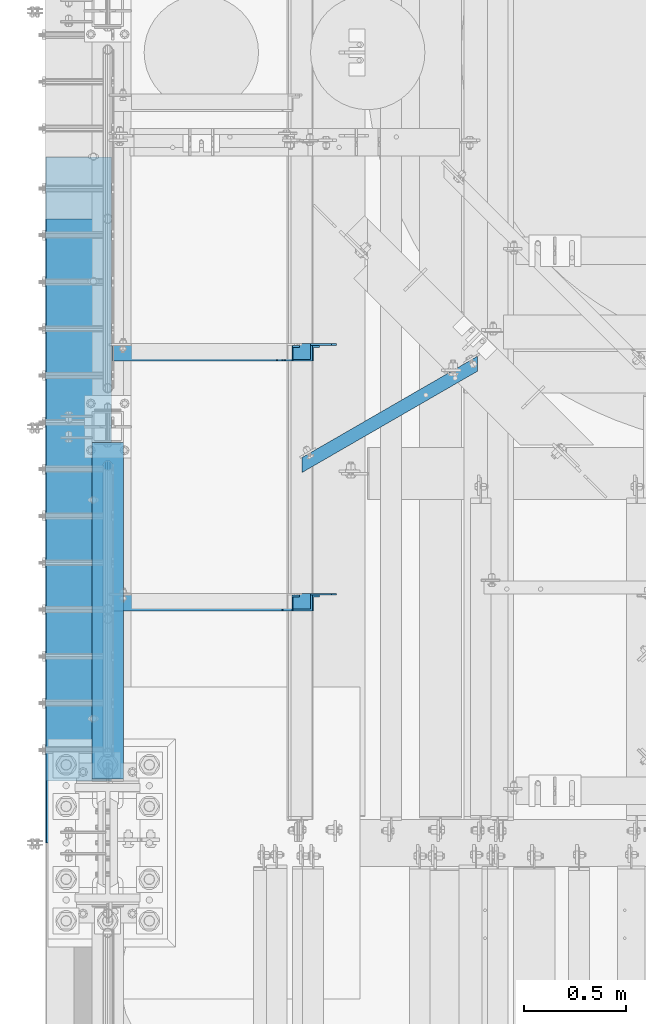
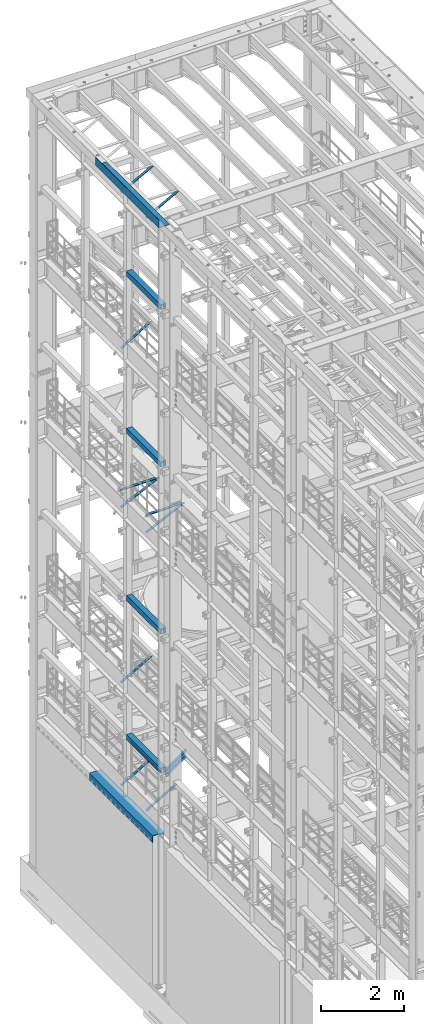
# One storey, part 1043 of 1876: 10 beams, 8 members, 18 elements without a shape of their own.
"""IFC2X3 building model written with IfcOpenShell, lengths in millimetres."""

import ifcopenshell
import ifcopenshell.guid

model = None  # the IFC model being written
_history = None  # IfcOwnerHistory: only IFC2X3 demands one
_inside = {}  # id of a spatial element -> (the spatial element, [elements in it])
_under = {}  # id of a project, library or spatial element -> (it, [spatial elements below it])
_declared = {}  # id of a project -> (the project, [libraries it declares])
_typed = {}  # id of a type object -> (the type object, [elements of that type])
_made_of = {}  # id of a material, layer set ... -> (it, [elements and type objects made of it])


def new_model(schema):
    """Start an empty IFC model of exactly this schema.

    Asked for "IFC4X3", IfcOpenShell would pick the latest addendum, in which some entities
    have other attributes; the version numbers below select the first issue.
    IFC2X3 requires an IfcOwnerHistory on every rooted entity: one is made here for all.
    """
    global model, _history
    if schema == "IFC4X3":
        model = ifcopenshell.file(schema_version=(4, 3, 0, 0))
    else:
        model = ifcopenshell.file(schema=schema)
    _inside.clear()
    _under.clear()
    _declared.clear()
    _typed.clear()
    _made_of.clear()
    _history = None
    if model.schema == "IFC2X3":
        org = make("IfcOrganization", Name="unknown")
        user = make(
            "IfcPersonAndOrganization",
            ThePerson=make("IfcPerson", FamilyName="unknown"),
            TheOrganization=org,
        )
        app = make(
            "IfcApplication",
            ApplicationDeveloper=org,
            Version="unknown",
            ApplicationFullName="unknown",
            ApplicationIdentifier="unknown",
        )
        _history = make(
            "IfcOwnerHistory",
            OwningUser=user,
            OwningApplication=app,
            ChangeAction="ADDED",
            CreationDate=0,
        )
    return model


def make(cls, **values):
    """One entity of the class cls with the attributes given. An attribute that is None is left unset."""
    return model.create_entity(
        cls, **{name: value for name, value in values.items() if value is not None}
    )


def rooted(cls, **values):
    """An entity with a GlobalId (a new one), such as an element, a storey or a relation."""
    return make(cls, GlobalId=ifcopenshell.guid.new(), OwnerHistory=_history, **values)


def si_unit(unit_type, name, prefix=None):
    """IfcSIUnit, for example si_unit("LENGTHUNIT", "METRE", prefix="MILLI")."""
    return make("IfcSIUnit", UnitType=unit_type, Prefix=prefix, Name=name)


def assignment(units):
    """IfcUnitAssignment: the units of a project."""
    return None if units is None else make("IfcUnitAssignment", Units=units)


def point(xyz):
    """IfcCartesianPoint."""
    return None if xyz is None else make("IfcCartesianPoint", Coordinates=xyz)


def direction(xyz):
    """IfcDirection."""
    return None if xyz is None else make("IfcDirection", DirectionRatios=xyz)


def frame(location, z_axis=None, x_axis=None):
    """IfcAxis2Placement3D, a coordinate frame: its origin and axes. An axis left out is left unset."""
    return make(
        "IfcAxis2Placement3D",
        Location=point(location),
        Axis=direction(z_axis),
        RefDirection=direction(x_axis),
    )


def origin_with_axes():
    """The frame at (0, 0, 0) with the z axis (0, 0, 1) and the x axis (1, 0, 0) written out."""
    return frame((0.0, 0.0, 0.0), z_axis=(0.0, 0.0, 1.0), x_axis=(1.0, 0.0, 0.0))


def place(relative_to, where):
    """IfcLocalPlacement: puts the frame where relative to a parent placement (None: the world)."""
    return make(
        "IfcLocalPlacement", PlacementRelTo=relative_to, RelativePlacement=where
    )


def context(
    kind, dimensions, precision=None, world=None, true_north=None, identifier=None
):
    """IfcGeometricRepresentationContext, for example the 3D "Model" context."""
    return make(
        "IfcGeometricRepresentationContext",
        ContextIdentifier=identifier,
        ContextType=kind,
        CoordinateSpaceDimension=dimensions,
        Precision=precision,
        WorldCoordinateSystem=world,
        TrueNorth=true_north,
    )


def subcontext(parent, identifier, kind, view, scale=None):
    """IfcGeometricRepresentationSubContext, for example "Body" below "Model"."""
    return make(
        "IfcGeometricRepresentationSubContext",
        ContextIdentifier=identifier,
        ContextType=kind,
        ParentContext=parent,
        TargetScale=scale,
        TargetView=view,
    )


def project(units=None, contexts=None):
    """IfcProject with its units and contexts."""
    return rooted(
        "IfcProject",
        Name="project",
        RepresentationContexts=contexts,
        UnitsInContext=assignment(units),
    )


def spatial(cls, under=None, at=None, **own):
    """A site, building, storey or space (cls), placed at a placement, below another one or the project."""
    s = rooted(cls, ObjectPlacement=at, **own)
    if under is not None:
        _under.setdefault(under.id(), (under, []))[1].append(s)
    return s


def faces_of(points, faces, orient=None, outer=None):
    """IfcFace entities. A face is a list of loops; a loop is a list of indices into points, from 0.

    orient and outer hold one flag for each loop. By default every Orientation is true, the
    first loop of a face is its IfcFaceOuterBound and the others are IfcFaceBound.
    """
    made = []
    for i, loops in enumerate(faces):
        bounds = []
        for j, loop in enumerate(loops):
            is_outer = j == 0 if outer is None else outer[i][j]
            bounds.append(
                make(
                    "IfcFaceOuterBound" if is_outer else "IfcFaceBound",
                    Bound=make("IfcPolyLoop", Polygon=[points[k] for k in loop]),
                    Orientation=True if orient is None else orient[i][j],
                )
            )
        made.append(make("IfcFace", Bounds=bounds))
    return made


def faceted_brep(points, faces, orient=None, outer=None, voids=None):
    """IfcFacetedBrep: a solid bounded by flat faces; with voids (closed shells), ...WithVoids."""
    shared = [point(p) for p in points]
    hull = make("IfcClosedShell", CfsFaces=faces_of(shared, faces, orient, outer))
    if voids is None:
        return make("IfcFacetedBrep", Outer=hull)
    return make(
        "IfcFacetedBrepWithVoids",
        Outer=hull,
        Voids=[
            make(cls, CfsFaces=faces_of(shared, fs, o, b)) for cls, fs, o, b in voids
        ],
    )


def shape(context_of_items, identifier, shape_type, items):
    """IfcShapeRepresentation: the items that make up one representation, for example the "Body"."""
    return make(
        "IfcShapeRepresentation",
        ContextOfItems=context_of_items,
        RepresentationIdentifier=identifier,
        RepresentationType=shape_type,
        Items=items,
    )


def material(Name=None, Category=None):
    """IfcMaterial."""
    return make("IfcMaterial", Name=Name, Category=Category)


def made_of(thing, what):
    """Note that an element or type object is made of a material, layer set ...; save() writes the relation."""
    if what is not None:
        _made_of.setdefault(what.id(), (what, []))[1].append(thing)
    return thing


def type_object(cls, material=None, **own):
    """A type object (cls), such as IfcWallType, which elements share."""
    return made_of(rooted(cls, **own), material)


def element(
    cls,
    number,
    at=None,
    inside=None,
    cuts=None,
    type_object=None,
    material=None,
    context=None,
    identifier="Body",
    shape_type=None,
    held_by="IfcProductDefinitionShape",
    body=None,
    shapes=None,
    **own,
):
    """One element of the class cls, such as IfcWall. Its Tag is "e" and its number.

    at: its placement. inside: the storey or other place that contains it. cuts: it is an
    opening in that element (IfcRelVoidsElement). A single representation is given by context,
    identifier, shape_type and body (its items); several are given by shapes. held_by: the class
    of the entity that holds the representations. save() writes the other relations.
    """
    e = rooted(cls, Tag="e%d" % number, ObjectPlacement=at, **own)
    if body is not None:
        shapes = [shape(context, identifier, shape_type, body)]
    if shapes is not None:
        e.Representation = make(held_by, Representations=shapes)
    if inside is not None:
        _inside.setdefault(inside.id(), (inside, []))[1].append(e)
    if cuts is not None:
        rooted(
            "IfcRelVoidsElement", RelatingBuildingElement=cuts, RelatedOpeningElement=e
        )
    if type_object is not None:
        _typed.setdefault(type_object.id(), (type_object, []))[1].append(e)
    return made_of(e, material)


def aggregate(whole, parts):
    """IfcRelAggregates: a whole, such as a stair, and the parts it consists of."""
    return rooted("IfcRelAggregates", RelatingObject=whole, RelatedObjects=parts)


def save(model, path):
    """Write the relations noted so far, then the file.

    IfcRelAggregates (storeys below a building ...), IfcRelContainedInSpatialStructure (elements
    in a storey), IfcRelDefinesByType, IfcRelAssociatesMaterial and IfcRelDeclares: one each for
    every whole, place, type object, material and project.
    """
    for whole, parts in _under.values():
        aggregate(whole, parts)
    for where, things in _inside.values():
        rooted(
            "IfcRelContainedInSpatialStructure",
            RelatedElements=things,
            RelatingStructure=where,
        )
    for kind, things in _typed.values():
        rooted("IfcRelDefinesByType", RelatedObjects=things, RelatingType=kind)
    for what, things in _made_of.values():
        rooted("IfcRelAssociatesMaterial", RelatedObjects=things, RelatingMaterial=what)
    for by, libraries in _declared.values():
        rooted("IfcRelDeclares", RelatingContext=by, RelatedDefinitions=libraries)
    model.write(path)


model = new_model("IFC2X3")

# Units and contexts
model_context = context("Model", 3, precision=1e-05, world=origin_with_axes())
body_context = subcontext(model_context, "Body", "Model", "MODEL_VIEW")
ifc_project = project(units=[si_unit("LENGTHUNIT", "METRE", prefix="MILLI"), si_unit("AREAUNIT", "SQUARE_METRE"), si_unit("VOLUMEUNIT", "CUBIC_METRE"), si_unit("MASSUNIT", "GRAM", prefix="KILO"), si_unit("TIMEUNIT", "SECOND"), si_unit("PLANEANGLEUNIT", "RADIAN"), si_unit("SOLIDANGLEUNIT", "STERADIAN"), si_unit("THERMODYNAMICTEMPERATUREUNIT", "DEGREE_CELSIUS"), si_unit("LUMINOUSINTENSITYUNIT", "LUMEN")], contexts=[model_context])

# Site, building, storey
site_placement = place(None, origin_with_axes())
site = spatial("IfcSite", under=ifc_project, at=site_placement, CompositionType="ELEMENT")
building_placement = place(site_placement, origin_with_axes())
building = spatial("IfcBuilding", under=site, at=building_placement, Name="Undefined", CompositionType="ELEMENT")
storey_placement = place(building_placement, origin_with_axes())
storey = spatial("IfcBuildingStorey", under=building, at=storey_placement, Name="Undefined", CompositionType="ELEMENT", Elevation=0.0)

# Assembly, beam
assembly_1_placement = place(storey_placement, origin_with_axes())
assembly_1 = element("IfcElementAssembly", 1, at=assembly_1_placement, inside=storey, Name="RAIL", AssemblyPlace="NOTDEFINED", PredefinedType="RIGID_FRAME")
ifc_material_1 = material()
beam_type_1 = type_object("IfcBeamType", Name="PIPE1-1/2SCH40", PredefinedType="NOTDEFINED")
beam_1_placement = place(assembly_1_placement, frame((-1.81898940354586e-12, 8035.925, 6207.125), z_axis=(0.0, 0.0, -1.0), x_axis=(0.0, 1.0, 0.0)))
beam_1 = element("IfcBeam", 2, at=beam_1_placement, type_object=beam_type_1, material=ifc_material_1, Name="RAIL", ObjectType="PIPE1-1/2SCH40", context=body_context, shape_type="Brep", body=[
    faceted_brep([(24.1300000000001, -20.4469999999999, 0.0), (34.3535000000002, -17.7076214311803, 10.2235000000001), (1416.6215, -17.7076214311801, 10.2235000000001), (1426.845, -20.4470000000001, 0.0), (41.8376214311802, -10.2235000000001, 17.7076214311819), (1409.13737856882, -10.2235000000001, 17.7076214311801), (44.5770000000002, 0.0, 20.4470000000001), (1406.398, 0.0, 20.4470000000001), (41.8376214311802, 10.2235000000001, 17.7076214311819), (1409.13737856882, 10.2235000000001, 17.7076214311801), (34.3535000000002, 17.7076214311803, 10.2235000000001), (1416.6215, 17.7076214311801, 10.2235000000001), (24.1300000000001, 20.4469999999999, 0.0), (1426.845, 20.4470000000001, 0.0), (13.9065000000001, 17.7076214311803, -10.2235000000001), (1437.0685, 17.7076214311801, -10.2235000000001), (6.42237856882002, 10.2235000000001, -17.7076214311819), (1444.55262143118, 10.2235000000001, -17.7076214311801), (3.68299999999999, 0.0, -20.4470000000001), (1447.292, 0.0, -20.4470000000001), (6.42237856882002, -10.2235000000001, -17.7076214311819), (1444.55262143118, -10.2235000000001, -17.7076214311801), (13.9065000000001, -17.7076214311803, -10.2235000000001), (1437.0685, -17.7076214311801, -10.2235000000001), (24.1299999999854, -24.1299999999992, 0.0), (12.0650000000064, -20.8971929933177, -12.0649999999987), (1438.91, -20.8971929933186, -12.0649999999996), (1426.845, -24.1300000000001, 0.0), (3.23280700668147, -12.0650000000001, -20.8971929933177), (1447.74219299332, -12.0649999999996, -20.8971929933186), (-1.45519152283669e-11, 0.0, -24.130000000001), (1450.975, 0.0, -24.1300000000001), (3.23280700668147, 12.0650000000001, -20.8971929933177), (1447.74219299332, 12.0649999999996, -20.8971929933186), (12.0650000000064, 20.8971929933177, -12.0649999999987), (1438.91, 20.8971929933186, -12.0649999999996), (24.1300000000047, 24.1299999999992, 0.0), (1426.845, 24.1300000000001, 0.0), (36.1949999999997, 20.8971929933184, 12.0649999999987), (1414.78, 20.8971929933186, 12.0649999999996), (45.0271929933187, 12.0650000000001, 20.8971929933177), (1405.94780700668, 12.0649999999996, 20.8971929933186), (48.2600000000002, 0.0, 24.130000000001), (1402.715, 0.0, 24.1300000000001), (45.0271929933187, -12.0650000000001, 20.8971929933177), (1405.94780700668, -12.0649999999996, 20.8971929933186), (36.1949999999997, -20.8971929933184, 12.0649999999987), (1414.78, -20.8971929933186, 12.0649999999996)], [[[0, 1, 2, 3]], [[1, 4, 5, 2]], [[4, 6, 7, 5]], [[6, 8, 9, 7]], [[8, 10, 11, 9]], [[10, 12, 13, 11]], [[12, 14, 15, 13]], [[14, 16, 17, 15]], [[16, 18, 19, 17]], [[18, 20, 21, 19]], [[20, 22, 23, 21]], [[22, 0, 3, 23]], [[24, 25, 26, 27]], [[25, 28, 29, 26]], [[28, 30, 31, 29]], [[30, 32, 33, 31]], [[32, 34, 35, 33]], [[34, 36, 37, 35]], [[36, 38, 39, 37]], [[38, 40, 41, 39]], [[40, 42, 43, 41]], [[42, 44, 45, 43]], [[44, 46, 47, 45]], [[46, 24, 27, 47]], [[29, 31, 33, 35, 37, 39, 41, 43, 45, 47, 27, 26], [5, 7, 9, 11, 13, 15, 17, 19, 21, 23, 3, 2]], [[46, 44, 42, 40, 38, 36, 34, 32, 30, 28, 25, 24], [22, 20, 18, 16, 14, 12, 10, 8, 6, 4, 1, 0]]]),
])
aggregate(assembly_1, [beam_1])

assembly_2_placement = place(storey_placement, origin_with_axes())
assembly_2 = element("IfcElementAssembly", 3, at=assembly_2_placement, inside=storey, Name="BEAM", AssemblyPlace="NOTDEFINED", PredefinedType="RIGID_FRAME")
ifc_material_2 = material()
beam_type_2 = type_object("IfcBeamType", Name="HSS6X6X3/8", PredefinedType="NOTDEFINED")
beam_2_placement = place(assembly_2_placement, frame((0.0, 7908.925, 19958.05), z_axis=(-1.0, 0.0, 0.0), x_axis=(0.0, 1.0, 0.0)))
beam_2 = element("IfcBeam", 4, at=beam_2_placement, type_object=beam_type_2, material=ifc_material_2, Name="BEAM", ObjectType="HSS6X6X3/8", context=body_context, shape_type="Brep", body=[
    faceted_brep([(22.2249999999995, 66.6749999999993, -66.675), (22.2249999999995, -66.6749999999993, -66.675), (1666.875, -66.6749999999993, -66.675), (1666.875, 66.6749999999993, -66.675), (22.2249999999995, -66.6749999999993, 66.675), (1666.875, -66.6749999999993, 66.675), (22.2249999999995, 66.6749999999993, 66.675), (1666.875, 66.6749999999993, 66.675), (22.2249999999995, 76.2000000000007, -76.2), (22.2249999999995, 76.2000000000007, 76.2), (1666.875, 76.2000000000007, 76.2), (1666.875, 76.2000000000007, -76.2), (22.2249999999995, -76.2000000000007, 76.2), (1666.875, -76.2000000000007, 76.2), (22.2249999999995, -76.2000000000007, -76.2), (1666.875, -76.2000000000007, -76.2)], [[[0, 1, 2, 3]], [[1, 4, 5, 2]], [[4, 6, 7, 5]], [[6, 0, 3, 7]], [[8, 9, 10, 11]], [[9, 12, 13, 10]], [[12, 14, 15, 13]], [[14, 8, 11, 15]], [[13, 15, 11, 10], [5, 7, 3, 2]], [[14, 12, 9, 8], [6, 4, 1, 0]]]),
])
aggregate(assembly_2, [beam_2])

assembly_3_placement = place(storey_placement, origin_with_axes())
assembly_3 = element("IfcElementAssembly", 5, at=assembly_3_placement, inside=storey, Name="BEAM", AssemblyPlace="NOTDEFINED", PredefinedType="RIGID_FRAME")
beam_3_placement = place(assembly_3_placement, frame((0.0, 7908.925, 15335.25), z_axis=(-1.0, 0.0, 0.0), x_axis=(0.0, 1.0, 0.0)))
beam_3 = element("IfcBeam", 6, at=beam_3_placement, type_object=beam_type_2, material=ifc_material_2, Name="BEAM", ObjectType="HSS6X6X3/8", context=body_context, shape_type="Brep", body=[
    faceted_brep([(22.2249999999995, 66.6749999999993, -66.675), (22.2249999999995, -66.6749999999993, -66.675), (1666.875, -66.6749999999993, -66.675), (1666.875, 66.6749999999993, -66.675), (22.2249999999995, -66.6749999999993, 66.675), (1666.875, -66.6749999999993, 66.675), (22.2249999999995, 66.6749999999993, 66.675), (1666.875, 66.6749999999993, 66.675), (22.2249999999995, 76.2000000000007, -76.2), (22.2249999999995, 76.2000000000007, 76.2), (1666.875, 76.2000000000007, 76.2), (1666.875, 76.2000000000007, -76.2), (22.2249999999995, -76.2000000000007, 76.2), (1666.875, -76.2000000000007, 76.2), (22.2249999999995, -76.2000000000007, -76.2), (1666.875, -76.2000000000007, -76.2)], [[[0, 1, 2, 3]], [[1, 4, 5, 2]], [[4, 6, 7, 5]], [[6, 0, 3, 7]], [[8, 9, 10, 11]], [[9, 12, 13, 10]], [[12, 14, 15, 13]], [[14, 8, 11, 15]], [[13, 15, 11, 10], [5, 7, 3, 2]], [[14, 12, 9, 8], [6, 4, 1, 0]]]),
])
aggregate(assembly_3, [beam_3])

assembly_4_placement = place(storey_placement, origin_with_axes())
assembly_4 = element("IfcElementAssembly", 7, at=assembly_4_placement, inside=storey, Name="BEAM", AssemblyPlace="NOTDEFINED", PredefinedType="RIGID_FRAME")
beam_4_placement = place(assembly_4_placement, frame((0.0, 7908.925, 10420.35), z_axis=(-1.0, 0.0, 0.0), x_axis=(0.0, 1.0, 0.0)))
beam_4 = element("IfcBeam", 8, at=beam_4_placement, type_object=beam_type_2, material=ifc_material_2, Name="BEAM", ObjectType="HSS6X6X3/8", context=body_context, shape_type="Brep", body=[
    faceted_brep([(22.2249999999995, 66.6749999999993, -66.675), (22.2249999999995, -66.6749999999993, -66.675), (1666.875, -66.6749999999993, -66.675), (1666.875, 66.6749999999993, -66.675), (22.2249999999995, -66.6749999999993, 66.675), (1666.875, -66.6749999999993, 66.675), (22.2249999999995, 66.6749999999993, 66.675), (1666.875, 66.6749999999993, 66.675), (22.2249999999995, 76.2000000000007, -76.2), (22.2249999999995, 76.2000000000007, 76.2), (1666.875, 76.2000000000007, 76.2), (1666.875, 76.2000000000007, -76.2), (22.2249999999995, -76.2000000000007, 76.2), (1666.875, -76.2000000000007, 76.2), (22.2249999999995, -76.2000000000007, -76.2), (1666.875, -76.2000000000007, -76.2)], [[[0, 1, 2, 3]], [[1, 4, 5, 2]], [[4, 6, 7, 5]], [[6, 0, 3, 7]], [[8, 9, 10, 11]], [[9, 12, 13, 10]], [[12, 14, 15, 13]], [[14, 8, 11, 15]], [[13, 15, 11, 10], [5, 7, 3, 2]], [[14, 12, 9, 8], [6, 4, 1, 0]]]),
])
aggregate(assembly_4, [beam_4])

assembly_5_placement = place(storey_placement, origin_with_axes())
assembly_5 = element("IfcElementAssembly", 9, at=assembly_5_placement, inside=storey, Name="BEAM", AssemblyPlace="NOTDEFINED", PredefinedType="RIGID_FRAME")
beam_5_placement = place(assembly_5_placement, frame((0.0, 7908.925, 6330.95), z_axis=(-1.0, 0.0, 0.0), x_axis=(0.0, 1.0, 0.0)))
beam_5 = element("IfcBeam", 10, at=beam_5_placement, type_object=beam_type_2, material=ifc_material_2, Name="BEAM", ObjectType="HSS6X6X3/8", context=body_context, shape_type="Brep", body=[
    faceted_brep([(22.2249999999995, 66.6749999999993, -66.675), (22.2249999999995, -66.6749999999993, -66.675), (1666.875, -66.6749999999993, -66.675), (1666.875, 66.6749999999993, -66.675), (22.2249999999995, -66.6749999999993, 66.675), (1666.875, -66.6749999999993, 66.675), (22.2249999999995, 66.6749999999993, 66.675), (1666.875, 66.6749999999993, 66.675), (22.2249999999995, 76.2000000000007, -76.2), (22.2249999999995, 76.2000000000007, 76.2), (1666.875, 76.2000000000007, 76.2), (1666.875, 76.2000000000007, -76.2), (22.2249999999995, -76.2000000000007, 76.2), (1666.875, -76.2000000000007, 76.2), (22.2249999999995, -76.2000000000007, -76.2), (1666.875, -76.2000000000007, -76.2)], [[[0, 1, 2, 3]], [[1, 4, 5, 2]], [[4, 6, 7, 5]], [[6, 0, 3, 7]], [[8, 9, 10, 11]], [[9, 12, 13, 10]], [[12, 14, 15, 13]], [[14, 8, 11, 15]], [[13, 15, 11, 10], [5, 7, 3, 2]], [[14, 12, 9, 8], [6, 4, 1, 0]]]),
])
aggregate(assembly_5, [beam_5])

# Assembly, member
assembly_6_placement = place(storey_placement, origin_with_axes())
assembly_6 = element("IfcElementAssembly", 11, at=assembly_6_placement, inside=storey, AssemblyPlace="NOTDEFINED", PredefinedType="RIGID_FRAME")
ifc_material_3 = material(Name="STEEL/A36")
member_type = type_object("IfcMemberType", Name="L3X3X3/8", PredefinedType="NOTDEFINED")
member_1_placement = place(assembly_6_placement, frame((19.2391985516099, 10010.775, 4577.2144175513), z_axis=(0.0, -1.0, 0.0), x_axis=(0.863139327949449, 0.0, 0.50496584097043)))
member_1 = element("IfcMember", 12, at=member_1_placement, type_object=member_type, material=ifc_material_3, ObjectType="L3X3X3/8", context=body_context, shape_type="Brep", body=[
    faceted_brep([(22.9902048797903, -38.0999999999885, -38.1000000000004), (22.9902048797903, -38.0999999999885, -28.5750000000007), (22.9902048798026, 28.5750000000021, -28.5750000000007), (22.9902048798026, 28.5750000000021, 38.1000000000004), (22.990204879804, 38.0999999999999, 38.1000000000004), (22.990204879804, 38.0999999999999, -38.1000000000004), (987.145928714758, 28.5750000002508, 38.1000000000004), (987.145928714761, 38.10000000025, 38.1000000000004), (987.145928714761, 38.10000000025, -38.1000000000004), (987.145928714736, -38.0999999997393, -38.1000000000004), (987.145928714736, -38.0999999997393, -28.5750000000007), (987.145928714758, 28.5750000002508, -28.5750000000007)], [[[0, 1, 2, 3, 4, 5]], [[4, 3, 6, 7]], [[5, 4, 7, 8]], [[0, 5, 8, 9]], [[1, 0, 9, 10]], [[2, 1, 10, 11]], [[3, 2, 11, 6]], [[10, 9, 8, 7, 6, 11]]]),
])
aggregate(assembly_6, [member_1])

assembly_7_placement = place(storey_placement, origin_with_axes())
assembly_7 = element("IfcElementAssembly", 13, at=assembly_7_placement, inside=storey, AssemblyPlace="NOTDEFINED", PredefinedType="RIGID_FRAME")
member_2_placement = place(assembly_7_placement, frame((19.0458151523234, 10010.775, 7599.70204228665), z_axis=(0.0, -1.0, 0.0), x_axis=(0.866088809372667, 0.0, 0.499890162215098)))
member_2 = element("IfcMember", 14, at=member_2_placement, type_object=member_type, material=ifc_material_3, ObjectType="L3X3X3/8", context=body_context, shape_type="Brep", body=[
    faceted_brep([(997.169004128596, -38.0999999996484, -28.5750000000007), (997.169004128596, -38.0999999996484, -38.1000000000004), (997.169004128632, 38.1000000003687, -38.1000000000004), (997.169004128632, 38.1000000003687, 38.1000000000004), (997.169004128628, 28.5750000003663, 38.1000000000004), (997.169004128628, 28.5750000003663, -28.5750000000007), (22.911911287435, 28.5750000000162, 38.1000000000004), (22.911911287435, 28.5750000000162, -28.5750000000007), (22.9119112874018, -38.0999999999995, -28.5750000000007), (22.9119112874018, -38.0999999999995, -38.1000000000004), (22.9119112874396, 38.1000000000186, -38.1000000000004), (22.9119112874396, 38.1000000000186, 38.1000000000004)], [[[0, 1, 2, 3, 4, 5]], [[5, 4, 6, 7]], [[0, 5, 7, 8]], [[1, 0, 8, 9]], [[2, 1, 9, 10]], [[3, 2, 10, 11]], [[4, 3, 11, 6]], [[10, 9, 8, 7, 6, 11]]]),
])
aggregate(assembly_7, [member_2])

assembly_8_placement = place(storey_placement, origin_with_axes())
assembly_8 = element("IfcElementAssembly", 15, at=assembly_8_placement, inside=storey, AssemblyPlace="NOTDEFINED", PredefinedType="RIGID_FRAME")
member_3_placement = place(assembly_8_placement, frame((19.9928945830509, 10010.775, 17420.4891604457), z_axis=(0.0, -1.0, 0.0), x_axis=(0.851257688514323, 0.0, 0.524747889700618)))
member_3 = element("IfcMember", 16, at=member_3_placement, type_object=member_type, material=ifc_material_3, ObjectType="L3X3X3/8", context=body_context, shape_type="Brep", body=[
    faceted_brep([(25.5909295921792, 38.1000000000076, -38.1000000000004), (25.5909295921938, -38.1000000000404, -38.1000000000004), (25.5909295921938, -38.1000000000404, -28.5750000000007), (25.5909295921811, 28.5750000000025, -28.5750000000007), (25.5909295921811, 28.5750000000025, 38.1000000000004), (25.5909295921792, 38.1000000000076, 38.1000000000004), (968.184782924762, 28.5749999994605, 38.1000000000004), (968.18478292476, 38.0999999994638, 38.1000000000004), (968.18478292476, 38.0999999994638, -38.1000000000004), (968.184782924776, -38.1000000005788, -38.1000000000004), (968.184782924776, -38.1000000005788, -28.5750000000007), (968.184782924762, 28.5749999994605, -28.5750000000007)], [[[0, 1, 2, 3, 4, 5]], [[5, 4, 6, 7]], [[0, 5, 7, 8]], [[1, 0, 8, 9]], [[2, 1, 9, 10]], [[3, 2, 10, 11]], [[4, 3, 11, 6]], [[10, 9, 8, 7, 6, 11]]]),
])
aggregate(assembly_8, [member_3])

assembly_9_placement = place(storey_placement, origin_with_axes())
assembly_9 = element("IfcElementAssembly", 17, at=assembly_9_placement, inside=storey, AssemblyPlace="NOTDEFINED", PredefinedType="RIGID_FRAME")
member_4_placement = place(assembly_9_placement, frame((19.2391985516099, 8791.575, 4577.2144175513), z_axis=(0.0, -1.0, 0.0), x_axis=(0.863139327949449, 0.0, 0.50496584097043)))
member_4 = element("IfcMember", 18, at=member_4_placement, type_object=member_type, material=ifc_material_3, ObjectType="L3X3X3/8", context=body_context, shape_type="Brep", body=[
    faceted_brep([(22.9902048797903, -38.0999999999885, -38.1000000000004), (22.9902048797903, -38.0999999999885, -28.5750000000007), (22.9902048798026, 28.5750000000021, -28.5750000000007), (22.9902048798026, 28.5750000000021, 38.1000000000004), (22.990204879804, 38.0999999999999, 38.1000000000004), (22.990204879804, 38.0999999999999, -38.1000000000004), (987.145928714758, 28.5750000002508, 38.1000000000004), (987.145928714761, 38.10000000025, 38.1000000000004), (987.145928714761, 38.10000000025, -38.1000000000004), (987.145928714736, -38.0999999997393, -38.1000000000004), (987.145928714736, -38.0999999997393, -28.5750000000007), (987.145928714758, 28.5750000002508, -28.5750000000007)], [[[0, 1, 2, 3, 4, 5]], [[4, 3, 6, 7]], [[5, 4, 7, 8]], [[0, 5, 8, 9]], [[1, 0, 9, 10]], [[2, 1, 10, 11]], [[3, 2, 11, 6]], [[10, 9, 8, 7, 6, 11]]]),
])
aggregate(assembly_9, [member_4])

assembly_10_placement = place(storey_placement, origin_with_axes())
assembly_10 = element("IfcElementAssembly", 19, at=assembly_10_placement, inside=storey, Name="BRACE", AssemblyPlace="NOTDEFINED", PredefinedType="RIGID_FRAME")
member_5_placement = place(assembly_10_placement, frame((16.6315097138003, 8791.575, 12754.6216849212), z_axis=(0.0, -1.0, 0.0), x_axis=(0.899693308993905, 0.0, 0.436522564997043)))
member_5 = element("IfcMember", 20, at=member_5_placement, type_object=member_type, material=ifc_material_3, Name="BRACE", ObjectType="L3X3X3/8", context=body_context, shape_type="Brep", body=[
    faceted_brep([(22.0561271426632, 38.1000000000149, -38.1000000000004), (22.0561271426632, 38.1000000000149, 38.1000000000004), (1112.8290707969, 38.0999999992546, 38.1000000000004), (1112.8290707969, 38.0999999992546, -38.1000000000004), (22.056127142665, 28.5750000000062, 38.1000000000004), (1112.8290707969, 28.5749999992458, 38.1000000000004), (22.056127142665, 28.5750000000062, -28.5750000000007), (1112.8290707969, 28.5749999992458, -28.5750000000007), (22.0561271426868, -38.1000000000422, -28.5750000000007), (1112.82907079693, -38.1000000008062, -28.5750000000007), (22.0561271426868, -38.1000000000422, -38.1000000000004), (1112.82907079693, -38.1000000008062, -38.1000000000004)], [[[0, 1, 2, 3]], [[1, 4, 5, 2]], [[4, 6, 7, 5]], [[6, 8, 9, 7]], [[8, 10, 11, 9]], [[10, 0, 3, 11]], [[5, 7, 9, 11, 3, 2]], [[10, 8, 6, 4, 1, 0]]]),
])
aggregate(assembly_10, [member_5])

assembly_11_placement = place(storey_placement, origin_with_axes())
assembly_11 = element("IfcElementAssembly", 21, at=assembly_11_placement, inside=storey, Name="BRACE", AssemblyPlace="NOTDEFINED", PredefinedType="RIGID_FRAME")
member_6_placement = place(assembly_11_placement, frame((16.6315097138003, 10010.775, 12754.6216849212), z_axis=(0.0, -1.0, 0.0), x_axis=(0.899693308993905, 0.0, 0.436522564997043)))
member_6 = element("IfcMember", 22, at=member_6_placement, type_object=member_type, material=ifc_material_3, Name="BRACE", ObjectType="L3X3X3/8", context=body_context, shape_type="Brep", body=[
    faceted_brep([(22.0561271426632, 38.1000000000149, -38.1000000000004), (22.0561271426632, 38.1000000000149, 38.1000000000004), (1112.8290707969, 38.0999999992546, 38.1000000000004), (1112.8290707969, 38.0999999992546, -38.1000000000004), (22.056127142665, 28.5750000000062, 38.1000000000004), (1112.8290707969, 28.5749999992458, 38.1000000000004), (22.056127142665, 28.5750000000062, -28.5750000000007), (1112.8290707969, 28.5749999992458, -28.5750000000007), (22.0561271426868, -38.1000000000422, -28.5750000000007), (1112.82907079693, -38.1000000008062, -28.5750000000007), (22.0561271426868, -38.1000000000422, -38.1000000000004), (1112.82907079693, -38.1000000008062, -38.1000000000004)], [[[0, 1, 2, 3]], [[1, 4, 5, 2]], [[4, 6, 7, 5]], [[6, 8, 9, 7]], [[8, 10, 11, 9]], [[10, 0, 3, 11]], [[5, 7, 9, 11, 3, 2]], [[10, 8, 6, 4, 1, 0]]]),
])
aggregate(assembly_11, [member_6])

assembly_12_placement = place(storey_placement, origin_with_axes())
assembly_12 = element("IfcElementAssembly", 23, at=assembly_12_placement, inside=storey, AssemblyPlace="NOTDEFINED", PredefinedType="RIGID_FRAME")
member_7_placement = place(assembly_12_placement, frame((18.2754879686868, 8791.575, 22001.0692535961), z_axis=(0.0, -1.0, 0.0), x_axis=(0.877448093107104, 0.0, 0.479671600058526)))
member_7 = element("IfcMember", 24, at=member_7_placement, type_object=member_type, material=ifc_material_3, ObjectType="L3X3X3/8", context=body_context, shape_type="Brep", body=[
    faceted_brep([(22.6152978728696, 38.0999999999985, -38.0999999999999), (22.6152978728696, 38.0999999999985, 38.0999999999999), (1025.78606203808, 38.1000000013628, 38.0999999999999), (1025.78606203808, 38.1000000013628, -38.0999999999999), (22.6152978728605, 28.5750000000044, 38.0999999999999), (1025.78606203807, 28.5750000013722, 38.0999999999999), (22.6152978728605, 28.5750000000044, -28.5749999999998), (1025.78606203807, 28.5750000013722, -28.5749999999998), (22.6152978728023, -38.0999999999367, -28.5749999999998), (1025.78606203801, -38.0999999985652, -28.5749999999998), (22.6152978728023, -38.0999999999367, -38.0999999999999), (1025.78606203801, -38.0999999985652, -38.0999999999999)], [[[0, 1, 2, 3]], [[1, 4, 5, 2]], [[4, 6, 7, 5]], [[6, 8, 9, 7]], [[8, 10, 11, 9]], [[10, 0, 3, 11]], [[5, 7, 9, 11, 3, 2]], [[10, 8, 6, 4, 1, 0]]]),
])
aggregate(assembly_12, [member_7])

assembly_13_placement = place(storey_placement, origin_with_axes())
assembly_13 = element("IfcElementAssembly", 25, at=assembly_13_placement, inside=storey, AssemblyPlace="NOTDEFINED", PredefinedType="RIGID_FRAME")
member_8_placement = place(assembly_13_placement, frame((18.2754879686868, 10010.775, 22001.0692535961), z_axis=(0.0, -1.0, 0.0), x_axis=(0.877448093107104, 0.0, 0.479671600058526)))
member_8 = element("IfcMember", 26, at=member_8_placement, type_object=member_type, material=ifc_material_3, ObjectType="L3X3X3/8", context=body_context, shape_type="Brep", body=[
    faceted_brep([(22.6152978728696, 38.0999999999985, -38.0999999999999), (22.6152978728696, 38.0999999999985, 38.0999999999999), (1025.78606203808, 38.1000000013628, 38.0999999999999), (1025.78606203808, 38.1000000013628, -38.0999999999999), (22.6152978728605, 28.5750000000044, 38.0999999999999), (1025.78606203807, 28.5750000013722, 38.0999999999999), (22.6152978728605, 28.5750000000044, -28.5749999999998), (1025.78606203807, 28.5750000013722, -28.5749999999998), (22.6152978728023, -38.0999999999367, -28.5749999999998), (1025.78606203801, -38.0999999985652, -28.5749999999998), (22.6152978728023, -38.0999999999367, -38.0999999999999), (1025.78606203801, -38.0999999985652, -38.0999999999999)], [[[0, 1, 2, 3]], [[1, 4, 5, 2]], [[4, 6, 7, 5]], [[6, 8, 9, 7]], [[8, 10, 11, 9]], [[10, 0, 3, 11]], [[5, 7, 9, 11, 3, 2]], [[10, 8, 6, 4, 1, 0]]]),
])
aggregate(assembly_13, [member_8])

# Assembly, beam
assembly_14_placement = place(storey_placement, origin_with_axes())
assembly_14 = element("IfcElementAssembly", 27, at=assembly_14_placement, inside=storey, Name="ANGLE", AssemblyPlace="NOTDEFINED", PredefinedType="RIGID_FRAME")
beam_type_3 = type_object("IfcBeamType", Name="L3X3X3/8", PredefinedType="NOTDEFINED")
beam_6_placement = place(assembly_14_placement, frame((0.0, 8801.1, 13271.5), z_axis=(0.0, -1.0, 0.0), x_axis=(1.0, 0.0, 0.0)))
beam_6 = element("IfcBeam", 28, at=beam_6_placement, type_object=beam_type_3, material=ifc_material_3, Name="ANGLE", ObjectType="L3X3X3/8", context=body_context, shape_type="Brep", body=[
    faceted_brep([(115.886999817316, 38.0999999999985, 38.0999999999999), (115.886999817316, 28.5750000000007, 38.0999999999999), (990.600505801039, 28.5750000000007, 38.1000000000004), (990.60050580103, 38.1000000000004, 38.1000000000004), (115.88699895052, 28.5750000000007, -28.5749999999998), (990.600505067652, 28.5750000000007, -28.5750000000007), (1092.20000190903, 15.8750003814675, -28.5750000000007), (1092.20000180425, 15.8750003814675, -38.1000000000004), (990.600504962847, 15.8750003814675, -38.1000000000004), (990.600505067622, 15.8750003814675, -28.5750000000007), (990.600504962874, 38.1000000000004, -38.1000000000004), (115.886998826692, 38.0999999999985, -38.0999999999999), (115.88699882669, 12.699999237062, -38.0999999999999), (115.886998950515, 12.699999237062, -28.5749999999998), (38.8937432114558, 12.699999237062, -38.0999999999999), (38.8937433352807, 12.699999237062, -28.5749999999998), (7.14374321145577, -19.050000762938, -38.0999999999999), (7.14374333528067, -19.050000762938, -28.5749999999998), (7.1437499954859, -38.0999999999985, -38.0999999999999), (7.1437499954859, -38.0999999999985, -28.5749999999998), (1117.60000480063, -38.1000000000004, -28.5750000000007), (1117.60000152756, -9.52499923706273, -28.5750000000007), (1117.60000142278, -9.52499923706273, -38.1000000000004), (1117.60000480063, -38.1000000000004, -38.1000000000004)], [[[0, 1, 2, 3]], [[1, 4, 5, 2]], [[6, 7, 8, 9]], [[2, 5, 9, 8, 10, 3]], [[11, 0, 3, 10]], [[1, 0, 11, 12, 13, 4]], [[13, 12, 14, 15]], [[15, 14, 16, 17]], [[16, 18, 19, 17]], [[6, 9, 5, 4, 13, 15, 17, 19, 20, 21]], [[7, 6, 21, 22]], [[18, 16, 14, 12, 11, 10, 8, 7, 22, 23]], [[19, 18, 23, 20]], [[22, 21, 20, 23]]]),
])
aggregate(assembly_14, [beam_6])

assembly_15_placement = place(storey_placement, origin_with_axes())
assembly_15 = element("IfcElementAssembly", 29, at=assembly_15_placement, inside=storey, Name="ANGLE", AssemblyPlace="NOTDEFINED", PredefinedType="RIGID_FRAME")
beam_7_placement = place(assembly_15_placement, frame((0.0, 10020.3, 13271.5), z_axis=(0.0, -1.0, 0.0), x_axis=(1.0, 0.0, 0.0)))
beam_7 = element("IfcBeam", 30, at=beam_7_placement, type_object=beam_type_3, material=ifc_material_3, Name="ANGLE", ObjectType="L3X3X3/8", context=body_context, shape_type="Brep", body=[
    faceted_brep([(115.886999817316, 38.0999999999985, 38.0999999999999), (115.886999817316, 28.5750000000007, 38.0999999999999), (990.600505801039, 28.5750000000007, 38.1000000000004), (990.60050580103, 38.1000000000004, 38.1000000000004), (115.88699895052, 28.5750000000007, -28.5749999999998), (990.600505067652, 28.5750000000007, -28.5750000000007), (1092.20000190903, 15.8750003814675, -28.5750000000007), (1092.20000180425, 15.8750003814675, -38.1000000000004), (990.600504962847, 15.8750003814675, -38.1000000000004), (990.600505067622, 15.8750003814675, -28.5750000000007), (990.600504962874, 38.1000000000004, -38.1000000000004), (115.886998826692, 38.0999999999985, -38.0999999999999), (115.88699882669, 12.699999237062, -38.0999999999999), (115.886998950515, 12.699999237062, -28.5749999999998), (38.8937432114558, 12.699999237062, -38.0999999999999), (38.8937433352807, 12.699999237062, -28.5749999999998), (7.14374321145577, -19.050000762938, -38.0999999999999), (7.14374333528067, -19.050000762938, -28.5749999999998), (7.1437499954859, -38.0999999999985, -38.0999999999999), (7.1437499954859, -38.0999999999985, -28.5749999999998), (1117.60000480063, -38.1000000000004, -28.5750000000007), (1117.60000152756, -9.52499923706273, -28.5750000000007), (1117.60000142278, -9.52499923706273, -38.1000000000004), (1117.60000480063, -38.1000000000004, -38.1000000000004)], [[[0, 1, 2, 3]], [[1, 4, 5, 2]], [[6, 7, 8, 9]], [[2, 5, 9, 8, 10, 3]], [[11, 0, 3, 10]], [[1, 0, 11, 12, 13, 4]], [[13, 12, 14, 15]], [[15, 14, 16, 17]], [[16, 18, 19, 17]], [[6, 9, 5, 4, 13, 15, 17, 19, 20, 21]], [[7, 6, 21, 22]], [[18, 16, 14, 12, 11, 10, 8, 7, 22, 23]], [[19, 18, 23, 20]], [[22, 21, 20, 23]]]),
])
aggregate(assembly_15, [beam_7])

assembly_16_placement = place(storey_placement, origin_with_axes())
assembly_16 = element("IfcElementAssembly", 31, at=assembly_16_placement, inside=storey, Name="BENT PLATE", AssemblyPlace="NOTDEFINED", PredefinedType="RIGID_FRAME")
beam_type_4 = type_object("IfcBeamType", PredefinedType="NOTDEFINED")
beam_8_placement = place(assembly_16_placement, frame((2.28578142867657e-05, 9144.0, 22558.3750000001), z_axis=(0.0, 1.0, 0.0), x_axis=(-0.999999999968684, 0.0, -7.91400000071008e-06)))
beam_8 = element("IfcBeam", 32, at=beam_8_placement, type_object=beam_type_4, material=ifc_material_3, Name="BENT PLATE", context=body_context, shape_type="Brep", body=[
    faceted_brep([(9.877112461254e-10, -3.17499999999563, -1524.0), (9.877112461254e-10, -3.17499999999563, 1524.0), (-9.88620740827173e-10, 3.17500000000291, 1524.0), (-9.88620740827173e-10, 3.17500000000291, -1524.0), (298.449951181141, 3.17499990714714, 1524.0), (298.449951181141, 3.17499990714714, -1524.0), (304.799984389467, -3.1750000948341, -1524.0), (304.799984389467, -3.1750000948341, 1524.0), (298.448604036157, 236.934945778325, 1524.0), (298.448604036646, 236.934945778212, -1524.0), (304.798604036052, 236.934982372997, 1524.0), (304.798604036541, 236.934982372881, -1524.0)], [[[0, 1, 2, 3]], [[3, 2, 4, 5]], [[1, 0, 6, 7]], [[5, 4, 8, 9]], [[4, 2, 1, 7, 10, 8]], [[7, 6, 11, 10]], [[6, 0, 3, 5, 9, 11]], [[10, 11, 9, 8]]]),
])
aggregate(assembly_16, [beam_8])

assembly_17_placement = place(storey_placement, origin_with_axes())
assembly_17 = element("IfcElementAssembly", 33, at=assembly_17_placement, inside=storey, Name="BENT PLATE", AssemblyPlace="NOTDEFINED", PredefinedType="RIGID_FRAME")
beam_type_5 = type_object("IfcBeamType", PredefinedType="NOTDEFINED")
beam_9_placement = place(assembly_17_placement, frame((-298.449987792968, 9445.625, 4305.30000305175), z_axis=(0.0, 1.0, 0.0), x_axis=(0.0, 0.0, 1.0)))
beam_9 = element("IfcBeam", 34, at=beam_9_placement, type_object=beam_type_5, material=ifc_material_3, Name="BENT PLATE", context=body_context, shape_type="Brep", body=[
    faceted_brep([(0.0, -6.35000000000036, -1524.0), (0.0, -6.35000000000036, 1524.0), (0.0, 6.35000000000036, 1524.0), (0.0, 6.35000000000036, -1524.0), (190.499996948255, 6.35000000000218, 1524.0), (190.499996948255, 6.35000000000218, -1524.0), (203.199996948256, -6.34999999999854, -1524.0), (203.199996948256, -6.34999999999854, 1524.0), (190.499996948255, 303.212481689452, 1524.0), (190.499996948255, 303.212481689452, -1524.0), (203.199996948256, 315.912481689453, -1524.0), (203.199996948256, 315.912481689453, 1524.0), (2.81943357549608e-11, 303.212481689452, 1524.0), (2.81943357549608e-11, 303.212481689452, -1524.0), (2.81943357549608e-11, 315.912481689453, 1524.0), (2.81943357549608e-11, 315.912481689453, -1524.0)], [[[0, 1, 2, 3]], [[3, 2, 4, 5]], [[1, 0, 6, 7]], [[5, 4, 8, 9]], [[7, 6, 10, 11]], [[9, 8, 12, 13]], [[8, 4, 2, 1, 7, 11, 14, 12]], [[11, 10, 15, 14]], [[10, 6, 0, 3, 5, 9, 13, 15]], [[14, 15, 13, 12]]]),
])
aggregate(assembly_17, [beam_9])

assembly_18_placement = place(storey_placement, origin_with_axes())
assembly_18 = element("IfcElementAssembly", 35, at=assembly_18_placement, inside=storey, Name="BEAM", AssemblyPlace="NOTDEFINED", PredefinedType="RIGID_FRAME")
beam_type_6 = type_object("IfcBeamType", Name="C8X18.75", PredefinedType="NOTDEFINED")
beam_10_placement = place(assembly_18_placement, frame((752.474473769653, 9352.08322768508, 4981.575), z_axis=(0.0, 0.0, 1.0), x_axis=(0.866034972682248, 0.499983425816554, 0.0)))
beam_10 = element("IfcBeam", 36, at=beam_10_placement, type_object=beam_type_6, material=ifc_material_3, Name="BEAM", ObjectType="C8X18.75", context=body_context, shape_type="Brep", body=[
    faceted_brep([(245.630957998246, 31.7499999998745, -101.6), (245.630957998246, 31.7499999998745, 101.6), (1235.48705739414, 31.7499999994461, 101.6), (1235.48705739414, 31.7499999994461, -101.6), (208.970836247064, -31.75000000007, 101.6), (1198.82693564296, -31.7500000004975, 101.6), (208.970836247064, -31.75000000007, 97.3645500000002), (1198.82693564296, -31.7500000004975, 97.3645500000002), (238.298933648009, 19.0499999998856, 88.9012700000003), (1228.1550330439, 19.0499999994563, 88.9012700000003), (238.298933648009, 19.0499999998856, -88.9012700000003), (1228.1550330439, 19.0499999994563, -88.9012700000003), (208.970836247064, -31.75000000007, -97.3645500000002), (1198.82693564296, -31.7500000004975, -97.3645500000002), (208.970836247064, -31.75000000007, -101.6), (1198.82693564296, -31.7500000004975, -101.6)], [[[0, 1, 2, 3]], [[1, 4, 5, 2]], [[4, 6, 7, 5]], [[6, 8, 9, 7]], [[8, 10, 11, 9]], [[10, 12, 13, 11]], [[12, 14, 15, 13]], [[14, 0, 3, 15]], [[5, 7, 9, 11, 13, 15, 3, 2]], [[14, 12, 10, 8, 6, 4, 1, 0]]]),
])
aggregate(assembly_18, [beam_10])

save(model, "model.ifc")
